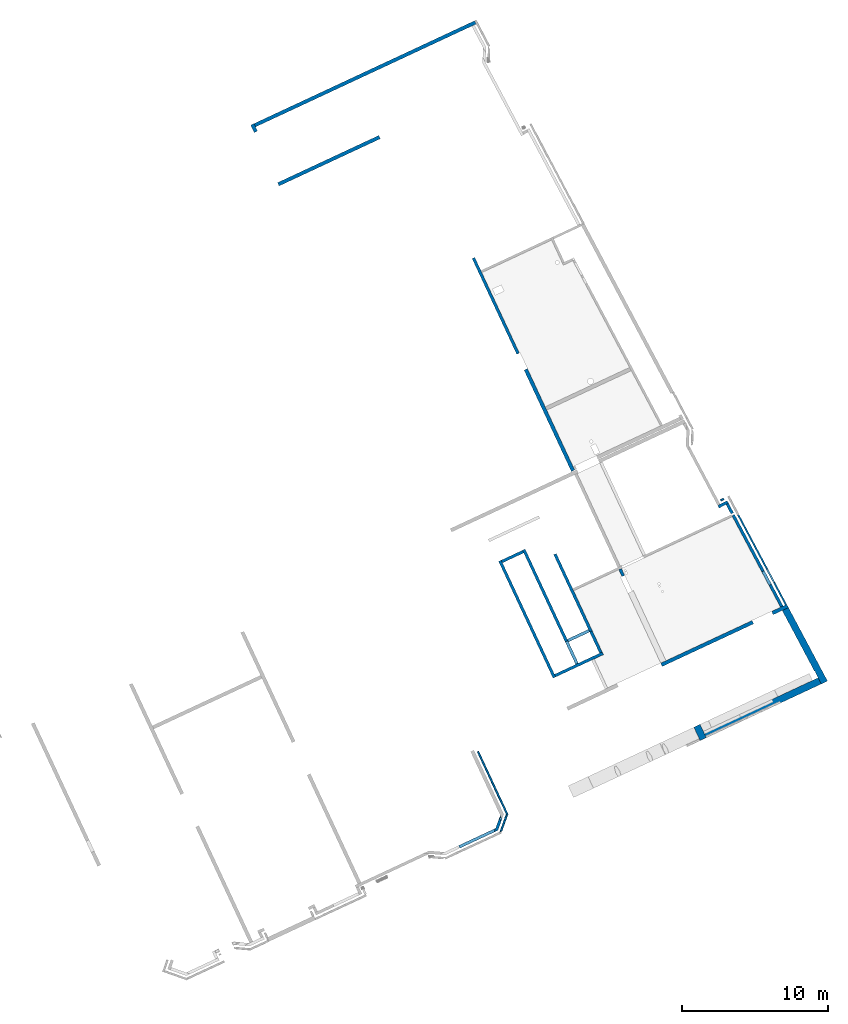
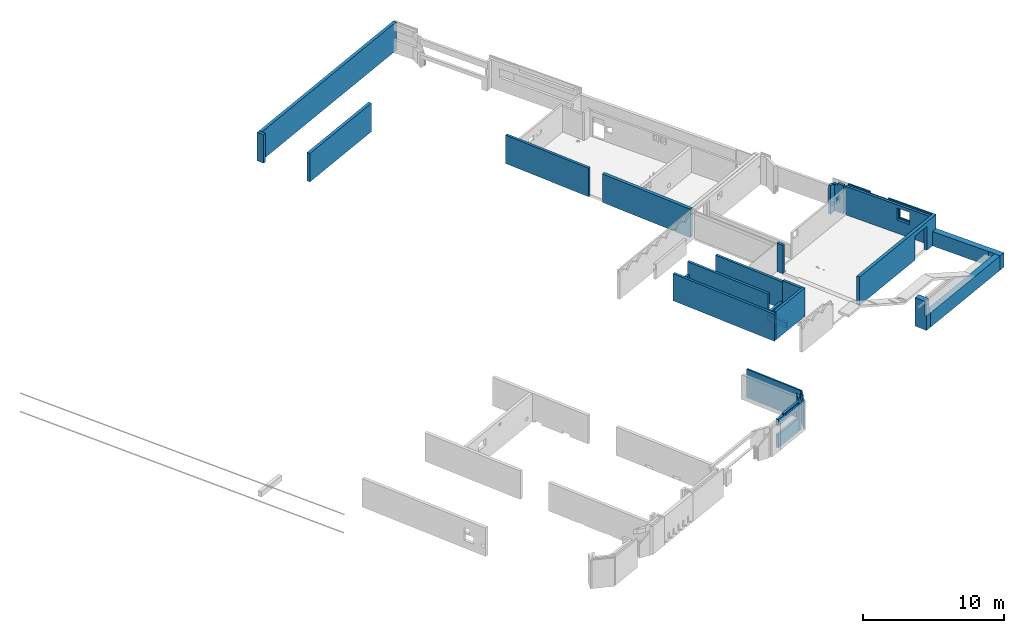
# One storey, part 3 of 13: 27 walls, 6 openings.
"""IFC2X3 building model written with IfcOpenShell, lengths in metres."""

import ifcopenshell
import ifcopenshell.guid

model = None  # the IFC model being written
_history = None  # IfcOwnerHistory: only IFC2X3 demands one
_inside = {}  # id of a spatial element -> (the spatial element, [elements in it])
_under = {}  # id of a project, library or spatial element -> (it, [spatial elements below it])
_declared = {}  # id of a project -> (the project, [libraries it declares])
_typed = {}  # id of a type object -> (the type object, [elements of that type])
_made_of = {}  # id of a material, layer set ... -> (it, [elements and type objects made of it])


def new_model(schema):
    """Start an empty IFC model of exactly this schema.

    Asked for "IFC4X3", IfcOpenShell would pick the latest addendum, in which some entities
    have other attributes; the version numbers below select the first issue.
    IFC2X3 requires an IfcOwnerHistory on every rooted entity: one is made here for all.
    """
    global model, _history
    if schema == "IFC4X3":
        model = ifcopenshell.file(schema_version=(4, 3, 0, 0))
    else:
        model = ifcopenshell.file(schema=schema)
    _inside.clear()
    _under.clear()
    _declared.clear()
    _typed.clear()
    _made_of.clear()
    _history = None
    if model.schema == "IFC2X3":
        org = make("IfcOrganization", Name="unknown")
        user = make(
            "IfcPersonAndOrganization",
            ThePerson=make("IfcPerson", FamilyName="unknown"),
            TheOrganization=org,
        )
        app = make(
            "IfcApplication",
            ApplicationDeveloper=org,
            Version="unknown",
            ApplicationFullName="unknown",
            ApplicationIdentifier="unknown",
        )
        _history = make(
            "IfcOwnerHistory",
            OwningUser=user,
            OwningApplication=app,
            ChangeAction="ADDED",
            CreationDate=0,
        )
    return model


def make(cls, **values):
    """One entity of the class cls with the attributes given. An attribute that is None is left unset."""
    return model.create_entity(
        cls, **{name: value for name, value in values.items() if value is not None}
    )


def entity(cls, *values):
    """Any entity or typed value of the class cls, its attributes in the order of the schema. None: left unset."""
    e = model.create_entity(cls)
    for i, value in enumerate(values):
        if value is not None:
            e[i] = value
    return e


def rooted(cls, **values):
    """An entity with a GlobalId (a new one), such as an element, a storey or a relation."""
    return make(cls, GlobalId=ifcopenshell.guid.new(), OwnerHistory=_history, **values)


def si_unit(unit_type, name, prefix=None):
    """IfcSIUnit, for example si_unit("LENGTHUNIT", "METRE", prefix="MILLI")."""
    return make("IfcSIUnit", UnitType=unit_type, Prefix=prefix, Name=name)


def converted_unit(unit_type, name, factor, base, dimensions=None, offset=None):
    """IfcConversionBasedUnit, such as the inch: factor (a typed value) times the base unit."""
    return make(
        "IfcConversionBasedUnit"
        if offset is None
        else "IfcConversionBasedUnitWithOffset",
        ConversionOffset=offset,
        Dimensions=None
        if dimensions is None
        else entity("IfcDimensionalExponents", *dimensions),
        UnitType=unit_type,
        Name=name,
        ConversionFactor=make(
            "IfcMeasureWithUnit", ValueComponent=factor, UnitComponent=base
        ),
    )


def derived_unit(unit_type, elements):
    """IfcDerivedUnit: a product of units, each with its exponent."""
    return make(
        "IfcDerivedUnit",
        Elements=[
            make("IfcDerivedUnitElement", Unit=unit, Exponent=power)
            for unit, power in elements
        ],
        UnitType=unit_type,
    )


def assignment(units):
    """IfcUnitAssignment: the units of a project."""
    return None if units is None else make("IfcUnitAssignment", Units=units)


def point(xyz):
    """IfcCartesianPoint."""
    return None if xyz is None else make("IfcCartesianPoint", Coordinates=xyz)


def direction(xyz):
    """IfcDirection."""
    return None if xyz is None else make("IfcDirection", DirectionRatios=xyz)


def frame(location, z_axis=None, x_axis=None):
    """IfcAxis2Placement3D, a coordinate frame: its origin and axes. An axis left out is left unset."""
    return make(
        "IfcAxis2Placement3D",
        Location=point(location),
        Axis=direction(z_axis),
        RefDirection=direction(x_axis),
    )


def frame_2d(location, x_axis=None):
    """IfcAxis2Placement2D, a coordinate frame in the plane: its origin and x axis."""
    return make(
        "IfcAxis2Placement2D", Location=point(location), RefDirection=direction(x_axis)
    )


def origin():
    """The frame at (0, 0, 0) with its axes left unset."""
    return frame((0.0, 0.0, 0.0))


def place(relative_to, where):
    """IfcLocalPlacement: puts the frame where relative to a parent placement (None: the world)."""
    return make(
        "IfcLocalPlacement", PlacementRelTo=relative_to, RelativePlacement=where
    )


def context(
    kind, dimensions, precision=None, world=None, true_north=None, identifier=None
):
    """IfcGeometricRepresentationContext, for example the 3D "Model" context."""
    return make(
        "IfcGeometricRepresentationContext",
        ContextIdentifier=identifier,
        ContextType=kind,
        CoordinateSpaceDimension=dimensions,
        Precision=precision,
        WorldCoordinateSystem=world,
        TrueNorth=true_north,
    )


def subcontext(parent, identifier, kind, view, scale=None):
    """IfcGeometricRepresentationSubContext, for example "Body" below "Model"."""
    return make(
        "IfcGeometricRepresentationSubContext",
        ContextIdentifier=identifier,
        ContextType=kind,
        ParentContext=parent,
        TargetScale=scale,
        TargetView=view,
    )


def project(units=None, contexts=None):
    """IfcProject with its units and contexts."""
    return rooted(
        "IfcProject",
        Name="project",
        RepresentationContexts=contexts,
        UnitsInContext=assignment(units),
    )


def spatial(cls, under=None, at=None, **own):
    """A site, building, storey or space (cls), placed at a placement, below another one or the project."""
    s = rooted(cls, ObjectPlacement=at, **own)
    if under is not None:
        _under.setdefault(under.id(), (under, []))[1].append(s)
    return s


def polyline(points):
    """IfcPolyline through the points."""
    return make("IfcPolyline", Points=[point(p) for p in points])


def profile(cls, at=None, kind="AREA", **sizes):
    """A parametric profile (cls). Its sizes go by their IFC names, for example OverallWidth=200.0."""
    return make(cls, ProfileType=kind, Position=at, **sizes)


def rectangle(**sizes):
    """IfcRectangleProfileDef."""
    return profile("IfcRectangleProfileDef", **sizes)


def outline(outer, holes=None, kind="AREA"):
    """IfcArbitraryClosedProfileDef: a profile drawn as a closed curve; with holes, ...WithVoids."""
    if holes is None:
        return make("IfcArbitraryClosedProfileDef", ProfileType=kind, OuterCurve=outer)
    return make(
        "IfcArbitraryProfileDefWithVoids",
        ProfileType=kind,
        OuterCurve=outer,
        InnerCurves=holes,
    )


def extrude(swept, where, along, depth):
    """IfcExtrudedAreaSolid: the profile swept, set in the frame where, extruded along a direction by depth."""
    return make(
        "IfcExtrudedAreaSolid",
        SweptArea=swept,
        Position=where,
        ExtrudedDirection=direction(along),
        Depth=depth,
    )


def clip(a, b, op="DIFFERENCE"):
    """IfcBooleanClippingResult: the solid a cut by the half space b."""
    return make(
        "IfcBooleanClippingResult", Operator=op, FirstOperand=a, SecondOperand=b
    )


def halfspace(plane, agree):
    """IfcHalfSpaceSolid: all space on one side of the plane z = 0 of the frame plane."""
    return make(
        "IfcHalfSpaceSolid",
        BaseSurface=make("IfcPlane", Position=plane),
        AgreementFlag=agree,
    )


def bounded_halfspace(plane, agree, where, boundary):
    """IfcPolygonalBoundedHalfSpace: a half space limited to a polygon's prism."""
    return make(
        "IfcPolygonalBoundedHalfSpace",
        BaseSurface=make("IfcPlane", Position=plane),
        AgreementFlag=agree,
        Position=where,
        PolygonalBoundary=boundary,
    )


def shape(context_of_items, identifier, shape_type, items):
    """IfcShapeRepresentation: the items that make up one representation, for example the "Body"."""
    return make(
        "IfcShapeRepresentation",
        ContextOfItems=context_of_items,
        RepresentationIdentifier=identifier,
        RepresentationType=shape_type,
        Items=items,
    )


def material(Name=None, Category=None):
    """IfcMaterial."""
    return make("IfcMaterial", Name=Name, Category=Category)


def layer(
    of_material, thickness, ventilated=None, Name=None, Category=None, Priority=None
):
    """IfcMaterialLayer: one layer of a wall or slab, of a material (None: an air gap)."""
    return make(
        "IfcMaterialLayer",
        Material=of_material,
        LayerThickness=thickness,
        IsVentilated=ventilated,
        Name=Name,
        Category=Category,
        Priority=Priority,
    )


def layer_set(layers, Name=None):
    """IfcMaterialLayerSet."""
    return make("IfcMaterialLayerSet", MaterialLayers=layers, LayerSetName=Name)


def layer_usage(for_layer_set, set_direction, sense, offset, extent=None):
    """IfcMaterialLayerSetUsage: how a layer set lies in its element."""
    return make(
        "IfcMaterialLayerSetUsage",
        ForLayerSet=for_layer_set,
        LayerSetDirection=set_direction,
        DirectionSense=sense,
        OffsetFromReferenceLine=offset,
        ReferenceExtent=extent,
    )


def made_of(thing, what):
    """Note that an element or type object is made of a material, layer set ...; save() writes the relation."""
    if what is not None:
        _made_of.setdefault(what.id(), (what, []))[1].append(thing)
    return thing


def type_object(cls, material=None, **own):
    """A type object (cls), such as IfcWallType, which elements share."""
    return made_of(rooted(cls, **own), material)


def element(
    cls,
    number,
    at=None,
    inside=None,
    cuts=None,
    type_object=None,
    material=None,
    context=None,
    identifier="Body",
    shape_type=None,
    held_by="IfcProductDefinitionShape",
    body=None,
    shapes=None,
    **own,
):
    """One element of the class cls, such as IfcWall. Its Tag is "e" and its number.

    at: its placement. inside: the storey or other place that contains it. cuts: it is an
    opening in that element (IfcRelVoidsElement). A single representation is given by context,
    identifier, shape_type and body (its items); several are given by shapes. held_by: the class
    of the entity that holds the representations. save() writes the other relations.
    """
    e = rooted(cls, Tag="e%d" % number, ObjectPlacement=at, **own)
    if body is not None:
        shapes = [shape(context, identifier, shape_type, body)]
    if shapes is not None:
        e.Representation = make(held_by, Representations=shapes)
    if inside is not None:
        _inside.setdefault(inside.id(), (inside, []))[1].append(e)
    if cuts is not None:
        rooted(
            "IfcRelVoidsElement", RelatingBuildingElement=cuts, RelatedOpeningElement=e
        )
    if type_object is not None:
        _typed.setdefault(type_object.id(), (type_object, []))[1].append(e)
    return made_of(e, material)


def aggregate(whole, parts):
    """IfcRelAggregates: a whole, such as a stair, and the parts it consists of."""
    return rooted("IfcRelAggregates", RelatingObject=whole, RelatedObjects=parts)


def save(model, path):
    """Write the relations noted so far, then the file.

    IfcRelAggregates (storeys below a building ...), IfcRelContainedInSpatialStructure (elements
    in a storey), IfcRelDefinesByType, IfcRelAssociatesMaterial and IfcRelDeclares: one each for
    every whole, place, type object, material and project.
    """
    for whole, parts in _under.values():
        aggregate(whole, parts)
    for where, things in _inside.values():
        rooted(
            "IfcRelContainedInSpatialStructure",
            RelatedElements=things,
            RelatingStructure=where,
        )
    for kind, things in _typed.values():
        rooted("IfcRelDefinesByType", RelatedObjects=things, RelatingType=kind)
    for what, things in _made_of.values():
        rooted("IfcRelAssociatesMaterial", RelatedObjects=things, RelatingMaterial=what)
    for by, libraries in _declared.values():
        rooted("IfcRelDeclares", RelatingContext=by, RelatedDefinitions=libraries)
    model.write(path)


model = new_model("IFC2X3")

# Units and contexts
model_context = context("Model", 3, precision=1e-05, world=origin(), true_north=direction((6.12303176911189e-17, 1.0)))
body_context = subcontext(model_context, "Body", "Model", "MODEL_VIEW")
ifc_project = project(units=[si_unit("LENGTHUNIT", "METRE"), si_unit("AREAUNIT", "SQUARE_METRE"), si_unit("VOLUMEUNIT", "CUBIC_METRE"), converted_unit("PLANEANGLEUNIT", "DEGREE", entity("IfcRatioMeasure", 0.0174532925199433), si_unit("PLANEANGLEUNIT", "RADIAN"), dimensions=[0, 0, 0, 0, 0, 0, 0]), si_unit("MASSUNIT", "GRAM", prefix="KILO"), derived_unit("MASSDENSITYUNIT", [(si_unit("MASSUNIT", "GRAM", prefix="KILO"), 1), (si_unit("LENGTHUNIT", "METRE"), -3)]), si_unit("TIMEUNIT", "SECOND"), si_unit("FREQUENCYUNIT", "HERTZ"), si_unit("THERMODYNAMICTEMPERATUREUNIT", "DEGREE_CELSIUS"), derived_unit("THERMALTRANSMITTANCEUNIT", [(si_unit("MASSUNIT", "GRAM", prefix="KILO"), 1), (si_unit("THERMODYNAMICTEMPERATUREUNIT", "KELVIN"), -1), (si_unit("TIMEUNIT", "SECOND"), -3)]), derived_unit("VOLUMETRICFLOWRATEUNIT", [(si_unit("LENGTHUNIT", "METRE"), 3), (si_unit("TIMEUNIT", "SECOND"), -1)]), si_unit("ELECTRICCURRENTUNIT", "AMPERE"), si_unit("ELECTRICVOLTAGEUNIT", "VOLT"), si_unit("POWERUNIT", "WATT"), si_unit("FORCEUNIT", "NEWTON", prefix="KILO"), si_unit("ILLUMINANCEUNIT", "LUX"), si_unit("LUMINOUSFLUXUNIT", "LUMEN"), si_unit("LUMINOUSINTENSITYUNIT", "CANDELA"), derived_unit("USERDEFINED", [(si_unit("MASSUNIT", "GRAM", prefix="KILO"), -1), (si_unit("LENGTHUNIT", "METRE"), -2), (si_unit("TIMEUNIT", "SECOND"), 3), (si_unit("LUMINOUSFLUXUNIT", "LUMEN"), 1)]), derived_unit("LINEARVELOCITYUNIT", [(si_unit("LENGTHUNIT", "METRE"), 1), (si_unit("TIMEUNIT", "SECOND"), -1)]), si_unit("PRESSUREUNIT", "PASCAL"), derived_unit("USERDEFINED", [(si_unit("LENGTHUNIT", "METRE"), -2), (si_unit("MASSUNIT", "GRAM", prefix="KILO"), 1), (si_unit("TIMEUNIT", "SECOND"), -2)])], contexts=[model_context])

# Site, building, storey
site_placement = place(None, frame((5.36960000000003, 43.3158000000006, 0.0), z_axis=(0.0, 0.0, 1.0), x_axis=(-0.422618261740703, 0.906307787036648, 0.0)))
site = spatial("IfcSite", under=ifc_project, at=site_placement, CompositionType="ELEMENT")
building_placement = place(site_placement, origin())
building = spatial("IfcBuilding", under=site, at=building_placement, CompositionType="ELEMENT")
storey_placement = place(building_placement, frame((0.0, 0.0, 2.56)))
storey = spatial("IfcBuildingStorey", under=building, at=storey_placement, CompositionType="ELEMENT", Elevation=2.56)

# Walls
ifc_material_1 = material(Name="C30/37 XC1")
ifc_layer_1 = layer(ifc_material_1, 0.25)
ifc_layer_set_1 = layer_set([ifc_layer_1])
ifc_layer_usage_1 = layer_usage(ifc_layer_set_1, "AXIS2", "NEGATIVE", 0.125)
wall_type_1 = type_object("IfcWallType", PredefinedType="NOTDEFINED", material=ifc_layer_set_1)
wall_1_placement = place(storey_placement, frame((20.3656620018759, 9.70752584902452, 0.0)))
element("IfcWallStandardCase", 1, at=wall_1_placement, inside=storey, type_object=wall_type_1, material=ifc_layer_usage_1, Name="XS1", context=body_context, shape_type="Clipping", body=[
    clip(extrude(rectangle(XDim=7.63499935530236, YDim=0.249999999999999, at=frame_2d((3.81749967765118, -1.59594559789866e-16), x_axis=(-1.0, 0.0))), origin(), (0.0, 0.0, 1.0), 2.47), halfspace(frame((0.0, 0.0, -2.56)), True)),
])
ifc_layer_2 = layer(ifc_material_1, 0.2)
ifc_layer_set_2 = layer_set([ifc_layer_2])
ifc_layer_usage_2 = layer_usage(ifc_layer_set_2, "AXIS2", "NEGATIVE", 0.1)
wall_type_2 = type_object("IfcWallType", PredefinedType="STANDARD", material=ifc_layer_set_2)
wall_2_placement = place(storey_placement, frame((10.0006608482378, 13.3325037603587, 0.0), z_axis=(0.0, 0.0, 1.0), x_axis=(0.0, 1.0, 0.0)))
element("IfcWallStandardCase", 2, at=wall_2_placement, inside=storey, type_object=wall_type_2, material=ifc_layer_usage_2, Name="XS1", context=body_context, shape_type="Clipping", body=[
    clip(extrude(rectangle(XDim=1.60000000000028, YDim=0.200000000000002, at=frame_2d((0.800000000000142, -1.73472347597681e-16), x_axis=(-1.0, 0.0))), origin(), (0.0, 0.0, 1.0), 0.640000000000001), halfspace(frame((0.0, 0.0, -2.56)), True)),
])
ifc_layer_usage_3 = layer_usage(ifc_layer_set_2, "AXIS2", "NEGATIVE", 0.1)
wall_3_placement = place(storey_placement, frame((16.8006608482376, 16.7325037603587, 0.0), z_axis=(0.0, 0.0, 1.0), x_axis=(0.0, -1.0, 0.0)))
element("IfcWallStandardCase", 3, at=wall_3_placement, inside=storey, type_object=wall_type_2, material=ifc_layer_usage_3, Name="XS1", context=body_context, shape_type="Clipping", body=[
    clip(extrude(rectangle(XDim=1.59999999999971, YDim=0.200000000000002, at=frame_2d((0.799999999999857, -1.73472347597681e-16), x_axis=(-1.0, 0.0))), origin(), (0.0, 0.0, 1.0), 1.3), halfspace(frame((0.0, 0.0, -2.56)), True)),
])
ifc_layer_usage_4 = layer_usage(ifc_layer_set_2, "AXIS2", "NEGATIVE", 0.1)
wall_4_placement = place(storey_placement, frame((29.200661357178, 9.73252584902451, 0.0)))
element("IfcWallStandardCase", 4, at=wall_4_placement, inside=storey, type_object=wall_type_2, material=ifc_layer_usage_4, Name="XS1", context=body_context, shape_type="Clipping", body=[
    clip(extrude(rectangle(XDim=7.20000014095195, YDim=0.199999999999999, at=frame_2d((3.60000007047597, -7.91033905045424e-16), x_axis=(-1.0, 0.0))), origin(), (0.0, 0.0, 1.0), 2.47), halfspace(frame((0.0, 0.0, -2.56)), True)),
])
ifc_layer_usage_5 = layer_usage(ifc_layer_set_2, "AXIS2", "NEGATIVE", 0.1)
wall_5_placement = place(storey_placement, frame((12.9206608482374, 9.63252584902463, 0.0), z_axis=(0.0, 0.0, 1.0), x_axis=(-1.0, 0.0, 0.0)))
element("IfcWallStandardCase", 5, at=wall_5_placement, inside=storey, type_object=wall_type_2, material=ifc_layer_usage_5, Name="XS1", context=body_context, shape_type="Clipping", body=[
    clip(extrude(rectangle(XDim=0.519999491059229, YDim=0.2, at=frame_2d((0.259999745529614, -1.11022302462516e-16), x_axis=(-1.0, 0.0))), origin(), (0.0, 0.0, 1.0), 2.47), halfspace(frame((0.0, 0.0, -2.56)), True)),
])
ifc_layer_usage_6 = layer_usage(ifc_layer_set_2, "AXIS2", "NEGATIVE", 0.1)
wall_6_placement = place(storey_placement, frame((9.90066084823775, 13.2325037603587, 0.0)))
element("IfcWallStandardCase", 6, at=wall_6_placement, inside=storey, type_object=wall_type_2, material=ifc_layer_usage_6, Name="XS1", context=body_context, shape_type="Clipping", body=[
    clip(extrude(rectangle(XDim=5.82511238135522, YDim=0.2, at=frame_2d((2.91255619067761, 1.35308431126191e-15), x_axis=(-1.0, 0.0))), origin(), (0.0, 0.0, 1.0), 2.35), halfspace(frame((0.0, 0.0, -2.56)), True)),
])
ifc_layer_usage_7 = layer_usage(ifc_layer_set_2, "AXIS2", "NEGATIVE", 0.1)
wall_7_placement = place(storey_placement, frame((8.10066084823749, 16.8325037603588, 0.0)))
element("IfcWallStandardCase", 7, at=wall_7_placement, inside=storey, type_object=wall_type_2, material=ifc_layer_usage_7, Name="XS1", context=body_context, shape_type="Clipping", body=[
    clip(extrude(rectangle(XDim=8.80000000000013, YDim=0.200000000000002, at=frame_2d((4.40000000000007, 1.11022302462516e-16), x_axis=(-1.0, 0.0))), origin(), (0.0, 0.0, 1.0), 2.35), halfspace(frame((0.0, 0.0, -2.56)), True)),
])
ifc_layer_usage_8 = layer_usage(ifc_layer_set_2, "AXIS2", "NEGATIVE", 0.1)
wall_8_placement = place(storey_placement, frame((16.9006608482376, 15.032503760359, 0.0), z_axis=(0.0, 0.0, 1.0), x_axis=(-1.0, 0.0, 0.0)))
element("IfcWallStandardCase", 8, at=wall_8_placement, inside=storey, type_object=wall_type_2, material=ifc_layer_usage_8, Name="XS1", context=body_context, shape_type="Clipping", body=[
    clip(clip(extrude(rectangle(XDim=6.99999999999984, YDim=0.200000000000002, at=frame_2d((3.49999999999992, 5.759281940243e-16), x_axis=(-1.0, 0.0))), origin(), (0.0, 0.0, 1.0), 2.35), bounded_halfspace(frame((1.67999999999998, -0.0999999999999989, 2.35), z_axis=(0.0, 0.0, -1.0), x_axis=(0.0, 1.0, 0.0)), True, frame((1.67999999999998, -0.0999999999999989, 2.35)), polyline([(0.0, 0.0), (0.739999999999901, 0.0), (2.24000000000005, 0.0), (2.24000000000005, 0.200000000000002), (0.0, 0.2), (0.0, 0.0)]))), halfspace(frame((0.0, 0.0, -2.56)), True)),
])
ifc_layer_usage_9 = layer_usage(ifc_layer_set_2, "AXIS2", "NEGATIVE", 0.1)
wall_9_placement = place(storey_placement, frame((10.0006608482378, 13.2325258490247, -0.159999999999999), z_axis=(0.0, 0.0, 1.0), x_axis=(-1.0, 0.0, 0.0)))
element("IfcWallStandardCase", 9, at=wall_9_placement, inside=storey, type_object=wall_type_2, material=ifc_layer_usage_9, context=body_context, shape_type="SweptSolid", body=[
    extrude(rectangle(XDim=1.60000000000029, YDim=0.2, at=frame_2d((0.900000000000181, -4.64905891561784e-16), x_axis=(-1.0, 0.0))), origin(), (0.0, 0.0, 1.0), 2.63),
])
ifc_layer_usage_10 = layer_usage(ifc_layer_set_2, "AXIS2", "NEGATIVE", 0.1)
wall_10_placement = place(storey_placement, frame((10.0006608482378, 15.032503760359, 0.0), z_axis=(0.0, 0.0, 1.0), x_axis=(-1.0, 0.0, 0.0)))
element("IfcWallStandardCase", 10, at=wall_10_placement, inside=storey, type_object=wall_type_2, material=ifc_layer_usage_10, context=body_context, shape_type="Clipping", body=[
    clip(extrude(rectangle(XDim=1.70000000000029, YDim=0.200000000000002, at=frame_2d((0.850000000000145, 2.22044604925031e-16), x_axis=(-1.0, 0.0))), origin(), (0.0, 0.0, 1.0), 0.500000000000001), halfspace(frame((0.0, 0.0, -2.56)), True)),
])
ifc_material_2 = material(Name="C30/37 XS1")
ifc_layer_3 = layer(ifc_material_2, 0.25)
ifc_layer_set_3 = layer_set([ifc_layer_3])
ifc_layer_usage_11 = layer_usage(ifc_layer_set_3, "AXIS2", "NEGATIVE", 0.125)
wall_type_3 = type_object("IfcWallType", PredefinedType="STANDARD", material=ifc_layer_set_3)
wall_11_placement = place(storey_placement, frame((46.6006614981315, 19.6823161808389, 0.0), z_axis=(0.0, 0.0, 1.0), x_axis=(0.0, -1.0, 0.0)))
element("IfcWallStandardCase", 11, at=wall_11_placement, inside=storey, type_object=wall_type_3, material=ifc_layer_usage_11, Name="XS1", context=body_context, shape_type="Clipping", body=[
    clip(extrude(rectangle(XDim=7.63056352608536, YDim=0.249999999999995, at=frame_2d((3.81528176304268, -1.73472347597681e-16), x_axis=(-1.0, 0.0))), origin(), (0.0, 0.0, 1.0), 2.47), halfspace(frame((0.0, 0.0, -2.56)), True)),
])

# Wall, opening
ifc_layer_usage_12 = layer_usage(ifc_layer_set_3, "AXIS2", "NEGATIVE", 0.125)
wall_12_placement = place(storey_placement, frame((5.80066084823741, 9.83252584902469, 0.0), z_axis=(0.0, 0.0, 1.0), x_axis=(0.0, -1.0, 0.0)))
wall_12 = element("IfcWallStandardCase", 12, at=wall_12_placement, inside=storey, type_object=wall_type_3, material=ifc_layer_usage_12, context=body_context, shape_type="Clipping", body=[
    clip(extrude(outline(polyline([(9.51015096177086, -0.125), (9.49710317292331, 0.125), (9.37693984877625, 0.125), (9.22677304154487, 0.125), (9.02650083511563, 0.125), (0.0, 0.125), (0.0, -0.125000000000001), (1.99345729407738, -0.125), (2.27345729407738, -0.125), (6.27472608878896, -0.125000000000001), (9.03954862396342, -0.125000000000001), (9.51015096177086, -0.125)])), origin(), (0.0, 0.0, 1.0), 2.47), halfspace(frame((0.0, 0.0, -2.56)), True)),
])
opening_1_placement = place(wall_12_placement, origin())
element("IfcOpeningElement", 13, at=opening_1_placement, cuts=wall_12, ObjectType="Opening", context=body_context, shape_type="SweptSolid", body=[
    extrude(rectangle(XDim=2.075, YDim=1.47, at=frame_2d((0.0, -1.11022302462516e-16), x_axis=(1.0, 0.0))), frame((7.62264475092439, -1.399, 1.0375), z_axis=(0.0, 1.0, 0.0), x_axis=(0.0, 0.0, -1.0)), (0.0, 0.0, 1.0), 3.048),
])

# Walls
ifc_layer_usage_13 = layer_usage(ifc_layer_set_3, "AXIS2", "NEGATIVE", 0.125)
wall_13_placement = place(storey_placement, frame((50.4987814117721, 19.5573161808388, 0.0)))
element("IfcWallStandardCase", 14, at=wall_13_placement, inside=storey, type_object=wall_type_3, material=ifc_layer_usage_13, context=body_context, shape_type="Clipping", body=[
    clip(extrude(rectangle(XDim=0.560000000000089, YDim=0.250000000000002, at=frame_2d((0.280000000000045, 1.6306400674182e-15), x_axis=(-1.0, 0.0))), origin(), (0.0, 0.0, 1.0), 2.47), halfspace(frame((0.0, 0.0, -2.56)), True)),
])
ifc_layer_4 = layer(ifc_material_1, 0.2)
ifc_layer_set_4 = layer_set([ifc_layer_4])
ifc_layer_usage_14 = layer_usage(ifc_layer_set_4, "AXIS2", "NEGATIVE", 0.1)
wall_type_4 = type_object("IfcWallType", PredefinedType="STANDARD", material=ifc_layer_set_4)
wall_14_placement = place(storey_placement, frame((8.20066084823749, 16.7325037603588, 0.0), z_axis=(0.0, 0.0, 1.0), x_axis=(0.0, -1.0, 0.0)))
element("IfcWallStandardCase", 15, at=wall_14_placement, inside=storey, type_object=wall_type_4, material=ifc_layer_usage_14, context=body_context, shape_type="Clipping", body=[
    clip(extrude(rectangle(XDim=3.59997791133407, YDim=0.2, at=frame_2d((1.79998895566704, 1.45716771982052e-16), x_axis=(-1.0, 0.0))), origin(), (0.0, 0.0, 1.0), 2.47), halfspace(frame((0.0, 0.0, -2.56)), True)),
])
ifc_layer_5 = layer(ifc_material_2, 0.2)
ifc_layer_set_5 = layer_set([ifc_layer_5])
ifc_layer_usage_15 = layer_usage(ifc_layer_set_5, "AXIS2", "NEGATIVE", 0.0999999999999944)
wall_type_5 = type_object("IfcWallType", PredefinedType="STANDARD", material=ifc_layer_set_5)
wall_15_placement = place(storey_placement, frame((13.9725447301183, 1.02572897456698, 0.0), z_axis=(0.0, 0.0, 1.0), x_axis=(-0.0521202180987301, 0.998640817744469, 0.0)))
element("IfcWallStandardCase", 16, at=wall_15_placement, inside=storey, type_object=wall_type_5, material=ifc_layer_usage_15, context=body_context, shape_type="Clipping", body=[
    clip(clip(clip(clip(extrude(rectangle(XDim=0.729879163389651, YDim=0.199999999999991, at=frame_2d((0.364939581694825, 3.7470027081099e-16), x_axis=(-1.0, 0.0))), origin(), (0.0, 0.0, 1.0), 2.47), bounded_halfspace(frame((0.565175850202635, -0.0999999999999934, 2.47), z_axis=(0.0, 0.0, -1.0), x_axis=(-1.0, -1.43635354930144e-06, 0.0)), True, frame((0.565175850202635, -0.0999999999999934, 2.47)), polyline([(0.0, 0.0), (0.0, 0.199999999999991), (-0.185175881052159, 0.199999999999989), (-0.185175881056299, 0.0), (-0.0352966868129734, 0.0), (0.0, 0.0)]))), bounded_halfspace(frame((0.379999969146336, -0.099999999999991, 2.31), z_axis=(0.0, 0.0, -1.0), x_axis=(0.0, -1.0, 0.0)), True, frame((0.379999969146336, -0.099999999999991, 2.31), z_axis=(0.0, 0.0, -1.0), x_axis=(0.0, -1.0, 0.0)), polyline([(0.0, 0.0), (0.0, 0.379999969146337), (-0.199999999992123, 0.379999969150336), (-0.199999999996262, 0.179999969150348), (-0.199999999999989, 0.0), (0.0, 0.0)]))), bounded_halfspace(frame((0.379999969150476, 0.0999999999999975, 2.31), z_axis=(1.0, 0.0, 0.0), x_axis=(0.0, 0.0, 1.0)), True, frame((0.379999969150476, 0.0999999999999975, 2.31), z_axis=(1.0, 0.0, 0.0), x_axis=(0.0, 0.0, 1.0)), polyline([(0.0, 0.0), (0.16, 0.0), (0.16, 0.199999999999991), (0.0, 0.199999999999989), (0.0, 0.0)]))), halfspace(frame((0.0, 0.0, -2.56)), True)),
])
ifc_layer_usage_16 = layer_usage(ifc_layer_set_5, "AXIS2", "NEGATIVE", 0.0999999999999944)
wall_16_placement = place(storey_placement, frame((0.199496236146166, 24.9518693783568, 0.0), z_axis=(0.0, 0.0, 1.0), x_axis=(0.707106781150338, -0.707106781222757, 0.0)))
element("IfcWallStandardCase", 17, at=wall_16_placement, inside=storey, type_object=wall_type_5, material=ifc_layer_usage_16, context=body_context, shape_type="Clipping", body=[
    clip(clip(clip(clip(extrude(outline(polyline([(1.02337139218561, -0.099999999999992), (1.22337139216512, 0.099999999999996), (1.03305029805904, 0.0999999999999962), (0.282842712489087, 0.0999999999999963), (0.0, 0.0999999999999955), (0.200000000020472, -0.0999999999999925), (1.02337139218561, -0.099999999999992)])), origin(), (0.0, 0.0, 1.0), 2.47), bounded_halfspace(frame((1.12819435771131, 0.00482296553644017, 1.15), z_axis=(0.707106781150345, 0.70710678122275, 0.0), x_axis=(0.0, 0.0, -1.0)), True, frame((1.12819435771131, 0.00482296553644017, 1.15), z_axis=(0.707106781150345, 0.70710678122275, 0.0), x_axis=(0.0, 0.0, -1.0)), polyline([(0.0, 0.0), (0.0, 0.134600652971707), (-0.77, 0.1346006529717), (-0.769999999999999, 0.0), (0.0, 0.0)]))), bounded_halfspace(frame((0.738043650248667, -0.0999999999999903, 2.31), z_axis=(0.0, 0.0, -1.0), x_axis=(0.70710678122275, -0.707106781150345, 0.0)), True, frame((0.738043650248667, -0.0999999999999903, 2.31), z_axis=(0.0, 0.0, -1.0), x_axis=(0.70710678122275, -0.707106781150345, 0.0)), polyline([(0.0, 0.0), (-0.380454313670196, 0.380454313631242), (-0.663297026159286, 0.380454313631244), (-0.463297026138723, 0.180454313631161), (-0.28284271248897, 0.0), (0.0, 0.0)]))), bounded_halfspace(frame((0.538043650228281, 0.0999999999999188, 2.31), z_axis=(0.707106781150345, 0.70710678122275, 0.0), x_axis=(0.0, 0.0, 1.0)), True, frame((0.538043650228281, 0.0999999999999188, 2.31), z_axis=(0.707106781150345, 0.70710678122275, 0.0), x_axis=(0.0, 0.0, 1.0)), polyline([(0.0, 0.0), (0.16, 0.0), (0.16, 0.28284271248897), (0.0, 0.28284271248897), (0.0, 0.0)]))), halfspace(frame((0.0, 0.0, -2.56)), True)),
])

# Wall, opening
ifc_layer_usage_17 = layer_usage(ifc_layer_set_5, "AXIS2", "NEGATIVE", 0.0999999999999944)
wall_17_placement = place(storey_placement, frame((0.370206914268461, 27.6125258491926, 0.0), z_axis=(0.0, 0.0, 1.0), x_axis=(0.0, -1.0, 0.0)))
wall_17 = element("IfcWallStandardCase", 18, at=wall_17_placement, inside=storey, type_object=wall_type_5, material=ifc_layer_usage_17, context=body_context, shape_type="Clipping", body=[
    clip(clip(clip(clip(extrude(outline(polyline([(2.58994579272075, -0.0999999999999944), (2.78994579274122, 0.0999999999999944), (0.0, 0.0999999999999944), (0.0, -0.0999999999999944), (2.58994579272075, -0.0999999999999944)])), origin(), (0.0, 0.0, 1.0), 2.56), bounded_halfspace(frame((0.728646590072152, -0.0999999999999944, 2.56), z_axis=(0.0, 0.0, -1.0), x_axis=(0.0, -1.0, 0.0)), True, frame((0.728646590072152, -0.0999999999999944, 2.56)), polyline([(0.0, 0.0), (1.8612992026486, 0.0), (2.06129920266907, 0.199999999999989), (0.0, 0.199999999999989), (0.0, 0.0)]))), bounded_halfspace(frame((0.915117453208692, -0.0999999999999945, 2.31), z_axis=(-1.0, 0.0, 0.0), x_axis=(0.0, 0.0, 1.0)), True, frame((0.915117453208692, -0.0999999999999945, 2.31), z_axis=(-1.0, 0.0, 0.0), x_axis=(0.0, 0.0, 1.0)), polyline([(0.0, 0.0), (0.16, 0.0), (0.16, 0.199999999999989), (0.0, 0.200000000000044), (0.0, 0.0)]))), bounded_halfspace(frame((0.0, 0.0999999999999944, 2.47), z_axis=(0.0, 0.0, 1.0), x_axis=(0.0, 1.0, 0.0)), False, frame((0.0, 0.0999999999999944, 2.47)), polyline([(0.0, 0.0), (0.0, -0.199999999999989), (0.728646590072148, -0.199999999999989), (0.728646590072152, 0.0), (0.0, 0.0)]))), halfspace(frame((0.0, 0.0, -2.56)), True)),
])
opening_2_placement = place(storey_placement, frame((0.370206914268461, 27.6125258491926, 0.0), z_axis=(0.0, 0.0, 1.0), x_axis=(0.0, -1.0, 0.0)))
element("IfcOpeningElement", 19, at=opening_2_placement, cuts=wall_17, ObjectType="Opening", context=body_context, shape_type="SweptSolid", body=[
    extrude(outline(polyline([(-1.34497289636549, -0.0999999999999945), (1.24497289635526, -0.0999999999999943), (1.44497289637572, 0.0999999999999944), (-1.3449728963655, 0.0999999999999944), (-1.34497289636549, -0.0999999999999945)])), frame((1.34497289636549, 0.0, 1.15)), (0.0, 0.0, 1.0), 0.77),
])

ifc_layer_usage_18 = layer_usage(ifc_layer_set_5, "AXIS2", "NEGATIVE", 0.0999999999999944)
wall_18_placement = place(storey_placement, frame((5.92044882642753, 0.705616889254266, 0.0), z_axis=(0.0, 0.0, 1.0), x_axis=(0.998640817744505, 0.0521202180980344, 0.0)))
wall_18 = element("IfcWallStandardCase", 20, at=wall_18_placement, inside=storey, type_object=wall_type_5, material=ifc_layer_usage_18, context=body_context, shape_type="Clipping", body=[
    clip(clip(extrude(outline(polyline([(7.0898484179737, -0.0999999999999944), (7.0898484179737, 0.0999999999999944), (7.01495865094103, 0.0999999999999944), (0.0104382310780675, 0.0999999999999945), (0.0, -0.0999999999999944), (7.0898484179737, -0.0999999999999944)])), origin(), (0.0, 0.0, 1.0), 2.47), bounded_halfspace(frame((3.70010215647179, -0.0999999999999943, 2.47), z_axis=(0.0, 0.0, -1.0), x_axis=(1.43635424595945e-06, -1.0, 0.0)), True, frame((3.70010215647179, -0.0999999999999943, 2.47)), polyline([(0.0, 0.0), (1.27845121496055, 0.0), (1.07845121506574, 0.199999999999989), (0.0, 0.199999999999989), (0.0, 0.0)]))), halfspace(frame((0.0, 0.0, -2.56)), True)),
])
opening_3_placement = place(wall_18_placement, origin())
element("IfcOpeningElement", 21, at=opening_3_placement, cuts=wall_18, ObjectType="Opening", context=body_context, shape_type="SweptSolid", body=[
    extrude(rectangle(XDim=1.05, YDim=1.05, at=frame_2d((-2.77555756156289e-16, -4.9960036108132e-16), x_axis=(1.0, 0.0))), frame((2.22078347961952, -1.89396270312707, 1.66230000000007), z_axis=(0.0, 1.0, 0.0), x_axis=(0.0, 0.0, 1.0)), (0.0, 0.0, 1.0), 3.048),
])

# Walls
ifc_layer_usage_19 = layer_usage(ifc_layer_set_5, "AXIS2", "NEGATIVE", 0.0999999999999944)
wall_19_placement = place(storey_placement, frame((13.0006608482374, 1.07514133508106, 0.0), z_axis=(0.0, 0.0, 1.0), x_axis=(0.998640817744505, 0.0521202180980344, 0.0)))
element("IfcWallStandardCase", 22, at=wall_19_placement, inside=storey, type_object=wall_type_5, material=ifc_layer_usage_19, context=body_context, shape_type="Clipping", body=[
    clip(clip(clip(extrude(outline(polyline([(0.867987531547531, -0.0999999999999942), (0.867987531547393, 0.0999999999999946), (0.130389244557306, 0.0999999999999947), (0.119951013479242, -0.0999999999999942), (0.867987531547531, -0.0999999999999942)])), origin(), (0.0, 0.0, 1.0), 2.47), bounded_halfspace(frame((0.643370515522573, 0.0999999999999946, 2.31), z_axis=(0.0, 0.0, -1.0), x_axis=(1.0, 0.0, 0.0)), True, frame((0.643370515522573, 0.0999999999999946, 2.31), z_axis=(0.0, 0.0, -1.0), x_axis=(1.0, 0.0, 0.0)), polyline([(0.0, 0.0), (0.224617016024816, 0.0), (0.224617016028964, 0.199999999995496), (0.0, 0.199999999999989), (0.0, 0.0)]))), bounded_halfspace(frame((0.643370515526549, -0.0999999999999941, 2.31), z_axis=(-1.0, 0.0, 0.0), x_axis=(0.0, 0.0, 1.0)), True, frame((0.643370515526549, -0.0999999999999941, 2.31), z_axis=(-1.0, 0.0, 0.0), x_axis=(0.0, 0.0, 1.0)), polyline([(0.0, 0.0), (0.16, 0.0), (0.16, 0.199999999999989), (0.0, 0.199999999999989), (0.0, 0.0)]))), halfspace(frame((0.0, 0.0, -2.56)), True)),
])
ifc_layer_6 = layer(ifc_material_2, 0.25)
ifc_layer_set_6 = layer_set([ifc_layer_6])
ifc_layer_usage_20 = layer_usage(ifc_layer_set_6, "AXIS2", "NEGATIVE", 0.125)
wall_type_6 = type_object("IfcWallType", PredefinedType="STANDARD", material=ifc_layer_set_6)
wall_20_placement = place(storey_placement, frame((50.9337814117722, 19.4323161808388, 0.0), z_axis=(0.0, 0.0, 1.0), x_axis=(0.0, -1.0, 0.0)))
element("IfcWallStandardCase", 23, at=wall_20_placement, inside=storey, type_object=wall_type_6, material=ifc_layer_usage_20, context=body_context, shape_type="Clipping", body=[
    clip(extrude(outline(polyline([(16.6342688415883, -0.12500000000001), (16.6212210527486, 0.124999999999994), (0.0, 0.124999999999998), (0.0, -0.125000000000006), (16.6342688415883, -0.12500000000001)])), origin(), (0.0, 0.0, 1.0), 2.47), halfspace(frame((0.0, 0.0, -2.56)), True)),
])
ifc_layer_7 = layer(ifc_material_2, 0.12)
ifc_layer_set_7 = layer_set([ifc_layer_7])
ifc_layer_usage_21 = layer_usage(ifc_layer_set_7, "AXIS2", "NEGATIVE", 0.06)
wall_type_7 = type_object("IfcWallType", PredefinedType="STANDARD", material=ifc_layer_set_7)
wall_21_placement = place(storey_placement, frame((0.997859967844689, 23.7150994423366, 0.0), z_axis=(0.0, 0.0, 1.0), x_axis=(-0.707106781241824, 0.707106781131271, 0.0)))
element("IfcWallStandardCase", 24, at=wall_21_placement, inside=storey, type_object=wall_type_7, material=ifc_layer_usage_21, context=body_context, shape_type="Clipping", body=[
    clip(clip(clip(extrude(outline(polyline([(1.30054689174379, -0.0599999999999973), (1.18054689176256, 0.0600000000000022), (0.120000000018761, 0.0600000000000029), (0.0, -0.0599999999999977), (0.056006519054525, -0.0599999999999968), (1.30054689174379, -0.0599999999999973)])), origin(), (0.0, 0.0, 1.0), 2.47), bounded_halfspace(frame((0.431013166840085, 0.0600000000000015, 2.31), z_axis=(0.0, 0.0, -1.0), x_axis=(-0.707106781131265, 0.707106781241831, 0.0)), True, frame((0.431013166840085, 0.0600000000000015, 2.31), z_axis=(0.0, 0.0, -1.0), x_axis=(-0.707106781131265, 0.707106781241831, 0.0)), polyline([(0.0, 0.0), (-0.530000379579254, 0.530000379662127), (-0.699706007050759, 0.530000379662127), (-0.169705627471503, 0.0), (0.0, 0.0)]))), bounded_halfspace(frame((0.55101316682132, -0.0599999999999994, 2.31), z_axis=(-0.707106781241831, -0.707106781131265, 0.0), x_axis=(0.0, 0.0, 1.0)), True, frame((0.55101316682132, -0.0599999999999994, 2.31), z_axis=(-0.707106781241831, -0.707106781131265, 0.0), x_axis=(0.0, 0.0, 1.0)), polyline([(0.0, 0.0), (0.16, 0.0), (0.16, 0.169705627471508), (0.0, 0.169705627471503), (0.0, 0.0)]))), halfspace(frame((0.0, 0.0, -2.56)), True)),
])
ifc_layer_usage_22 = layer_usage(ifc_layer_set_7, "AXIS2", "NEGATIVE", 0.06)
wall_22_placement = place(storey_placement, frame((5.73055933516981, 23.6975258492111, 0.0), z_axis=(0.0, 0.0, 1.0), x_axis=(-1.0, 0.0, 0.0)))
element("IfcWallStandardCase", 25, at=wall_22_placement, inside=storey, type_object=wall_type_7, material=ifc_layer_usage_22, context=body_context, shape_type="Clipping", body=[
    clip(extrude(outline(polyline([(4.85997858795529, -0.06), (4.73997858793652, 0.0599999999999976), (4.72987554987445, 0.0599999999999975), (4.29584594222785, 0.0599999999999976), (4.16985345448317, 0.0599999999999964), (0.0, 0.0599999999999994), (0.0, -0.0599999999999994), (4.16985345448317, -0.0600000000000023), (4.69027296045725, -0.0600000000000016), (4.85997858795529, -0.06)])), origin(), (0.0, 0.0, 1.0), 2.47), halfspace(frame((0.0, 0.0, -2.56)), True)),
])

# Wall, openings
ifc_layer_usage_23 = layer_usage(ifc_layer_set_7, "AXIS2", "NEGATIVE", 0.06)
wall_23_placement = place(storey_placement, frame((14.2626284789808, 1.42126497183849, 0.0), z_axis=(0.0, 0.0, 1.0), x_axis=(0.0521202181179237, -0.998640817743467, 0.0)))
wall_23 = element("IfcWallStandardCase", 26, at=wall_23_placement, inside=storey, type_object=wall_type_7, material=ifc_layer_usage_23, context=body_context, shape_type="Clipping", body=[
    clip(clip(extrude(rectangle(XDim=0.529866602035295, YDim=0.119999999999999, at=frame_2d((0.264933301017648, -6.59194920871187e-17), x_axis=(-1.0, 0.0))), origin(), (0.0, 0.0, 1.0), 1.89386232866787), halfspace(frame((0.589866602032895, 0.0, 2.05695092841044), z_axis=(0.923639933971809, 0.0, -0.383261363005134), x_axis=(0.0, -1.0, 0.0)), False)), halfspace(frame((0.0, 0.0, -2.56)), True)),
])
opening_4_placement = place(wall_23_placement, origin())
element("IfcOpeningElement", 27, at=opening_4_placement, cuts=wall_23, ObjectType="Opening", context=body_context, shape_type="SweptSolid", body=[
    extrude(rectangle(XDim=2.24, YDim=0.12, at=frame_2d((-1.94289029309402e-16, 0.0), x_axis=(0.0, 1.0))), frame((0.0600000000047948, 0.0600000000023606, -0.32), z_axis=(0.0, 1.0, 0.0), x_axis=(1.0, 0.0, 0.0)), (0.0, 0.0, 1.0), 4.22),
])
opening_5_placement = place(wall_23_placement, origin())
element("IfcOpeningElement", 28, at=opening_5_placement, cuts=wall_23, ObjectType="Opening", context=body_context, shape_type="SweptSolid", body=[
    extrude(outline(polyline([(-0.914029642923721, -0.018437391775022), (0.468490624383624, -0.0184373917750218), (0.445539018540096, 0.036874783550044), (-0.914029642923721, -0.018437391775022)])), frame((0.256583866580547, 0.0599999999999959, 1.20565030947015), z_axis=(0.0, -1.0, 0.0), x_axis=(-0.383261363005134, 0.0, -0.923639933971809)), (0.0, 0.0, 1.0), 0.12),
])

# Wall, opening
ifc_layer_usage_24 = layer_usage(ifc_layer_set_7, "AXIS2", "NEGATIVE", 0.06)
wall_24_placement = place(storey_placement, frame((13.0006608482374, 0.764756762848038, 0.0), z_axis=(0.0, 0.0, 1.0), x_axis=(-0.998640817743463, -0.0521202181179964, 0.0)))
wall_24 = element("IfcWallStandardCase", 29, at=wall_24_placement, inside=storey, type_object=wall_type_7, material=ifc_layer_usage_24, context=body_context, shape_type="Clipping", body=[
    clip(clip(extrude(outline(polyline([(7.08149783311743, -0.06), (7.08776077176668, 0.0600000000000001), (0.128301598343033, 0.0600000000000001), (0.0, 0.0600000000000001), (0.0, -0.0600000000000001), (0.122038659693785, -0.06), (7.08149783311743, -0.06)])), origin(), (0.0, 0.0, 1.0), 2.47), bounded_halfspace(frame((3.37356894990136, -0.06, 2.31), z_axis=(0.0, 0.0, -1.0), x_axis=(-1.0, 0.0, 0.0)), True, frame((3.37356894990136, -0.06, 2.31), z_axis=(0.0, 0.0, -1.0), x_axis=(-1.0, 0.0, 0.0)), polyline([(0.0, 0.0), (1.42996269172701, 0.0), (1.54996269166456, 0.119999999938016), (0.0, 0.120000000000456), (0.0, 0.0)]))), halfspace(frame((0.0, 0.0, -2.56)), True)),
])
opening_6_placement = place(wall_24_placement, origin())
element("IfcOpeningElement", 30, at=opening_6_placement, cuts=wall_24, ObjectType="Opening", context=body_context, shape_type="SweptSolid", body=[
    extrude(rectangle(XDim=1.05, YDim=1.05, at=frame_2d((4.9960036108132e-16, -2.77555756156289e-16), x_axis=(0.0, 1.0))), frame((4.85288762678678, -1.464, 1.66230000000007), z_axis=(0.0, 1.0, 0.0), x_axis=(-1.0, 0.0, 0.0)), (0.0, 0.0, 1.0), 3.048),
])

# Walls
ifc_layer_8 = layer(ifc_material_2, 0.47)
ifc_layer_set_8 = layer_set([ifc_layer_8])
ifc_layer_usage_25 = layer_usage(ifc_layer_set_8, "AXIS2", "NEGATIVE", 0.235)
wall_type_8 = type_object("IfcWallType", PredefinedType="STANDARD", material=ifc_layer_set_8)
wall_25_placement = place(storey_placement, frame((0.2356608482374, 0.496829765523162, 0.0), z_axis=(0.0, 0.0, 1.0), x_axis=(0.0, 1.0, 0.0)))
element("IfcWallStandardCase", 31, at=wall_25_placement, inside=storey, type_object=wall_type_8, material=ifc_layer_usage_25, context=body_context, shape_type="Clipping", body=[
    clip(extrude(outline(polyline([(8.66569608348307, -0.235), (8.66569608348307, 0.235), (0.0, 0.235), (0.0245298430334001, -0.235), (8.66569608348307, -0.235)])), origin(), (0.0, 0.0, 1.0), 1.25), halfspace(frame((0.0, 0.0, -2.56)), True)),
])
ifc_layer_usage_26 = layer_usage(ifc_layer_set_8, "AXIS2", "NEGATIVE", 0.235)
wall_26_placement = place(storey_placement, frame((0.000660848237485803, 9.39752584900623, 0.0)))
element("IfcWallStandardCase", 32, at=wall_26_placement, inside=storey, type_object=wall_type_8, material=ifc_layer_usage_26, context=body_context, shape_type="Clipping", body=[
    clip(clip(clip(extrude(rectangle(XDim=0.999999999999913, YDim=0.469999999999999, at=frame_2d((0.499999999999956, -2.77555756156289e-17), x_axis=(-1.0, 0.0))), origin(), (0.0, 0.0, 1.0), 2.47), bounded_halfspace(frame((0.119999999995483, 0.235, 1.25), z_axis=(1.0, 0.0, 0.0), x_axis=(0.0, 1.0, 0.0)), True, frame((0.119999999995483, 0.235, 1.25), z_axis=(1.0, 0.0, 0.0), x_axis=(0.0, 1.0, 0.0)), polyline([(0.0, 0.0), (0.0, 1.22), (-0.47, 1.22), (-0.47, 0.0), (0.0, 0.0)]))), bounded_halfspace(frame((0.119999999995483, -0.235000000000001, 1.25), z_axis=(0.0, 0.0, -1.0), x_axis=(1.0, 0.0, 0.0)), True, frame((0.119999999995483, -0.235000000000001, 1.25), z_axis=(0.0, 0.0, -1.0), x_axis=(1.0, 0.0, 0.0)), polyline([(0.0, 0.0), (-0.119999999995483, 0.0), (-0.119999999995483, -0.47), (0.0, -0.47), (0.0, 0.0)]))), halfspace(frame((0.0, 0.0, -2.56)), True)),
])
ifc_layer_usage_27 = layer_usage(ifc_layer_set_8, "AXIS2", "NEGATIVE", 0.235)
wall_27_placement = place(storey_placement, frame((5.68790909949035, 0.558333980192601, 0.0), z_axis=(0.0, 0.0, 1.0), x_axis=(-0.998640817744512, -0.0521202180979027, 0.0)))
element("IfcWallStandardCase", 33, at=wall_27_placement, inside=storey, type_object=wall_type_8, material=ifc_layer_usage_27, context=body_context, shape_type="Clipping", body=[
    clip(clip(extrude(outline(polyline([(5.68272385742981, -0.235), (5.70725370046321, 0.235), (0.0245298430333999, 0.235), (0.0, -0.235), (5.21208417232108, -0.235), (5.68272385742981, -0.235)])), origin(), (0.0, 0.0, 1.0), 1.25), bounded_halfspace(frame((5.21232773897803, -0.230333181356745, -0.2), z_axis=(0.0521202180979101, 0.998640817744511, 0.0), x_axis=(0.998640817744511, -0.0521202180979101, 0.0)), True, frame((5.21232773897803, -0.230333181356745, -0.2), z_axis=(0.0521202180979101, 0.998640817744511, 0.0), x_axis=(0.998640817744511, -0.0521202180979101, 0.0)), polyline([(0.0, 0.0), (-0.529999999999999, 0.0), (-0.529999999999999, -1.45), (0.0, -1.45), (0.0, 0.0)]))), halfspace(frame((0.0, 0.0, -2.56)), True)),
])

save(model, "model.ifc")
